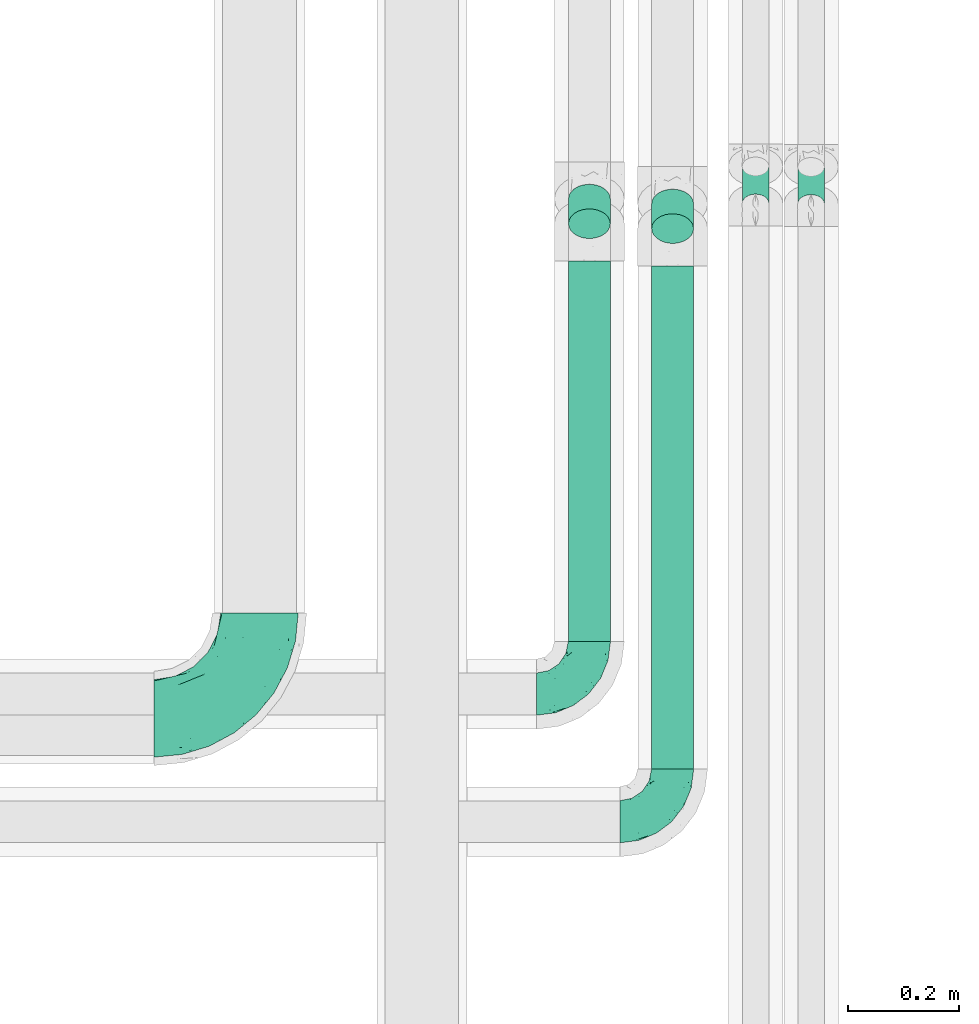
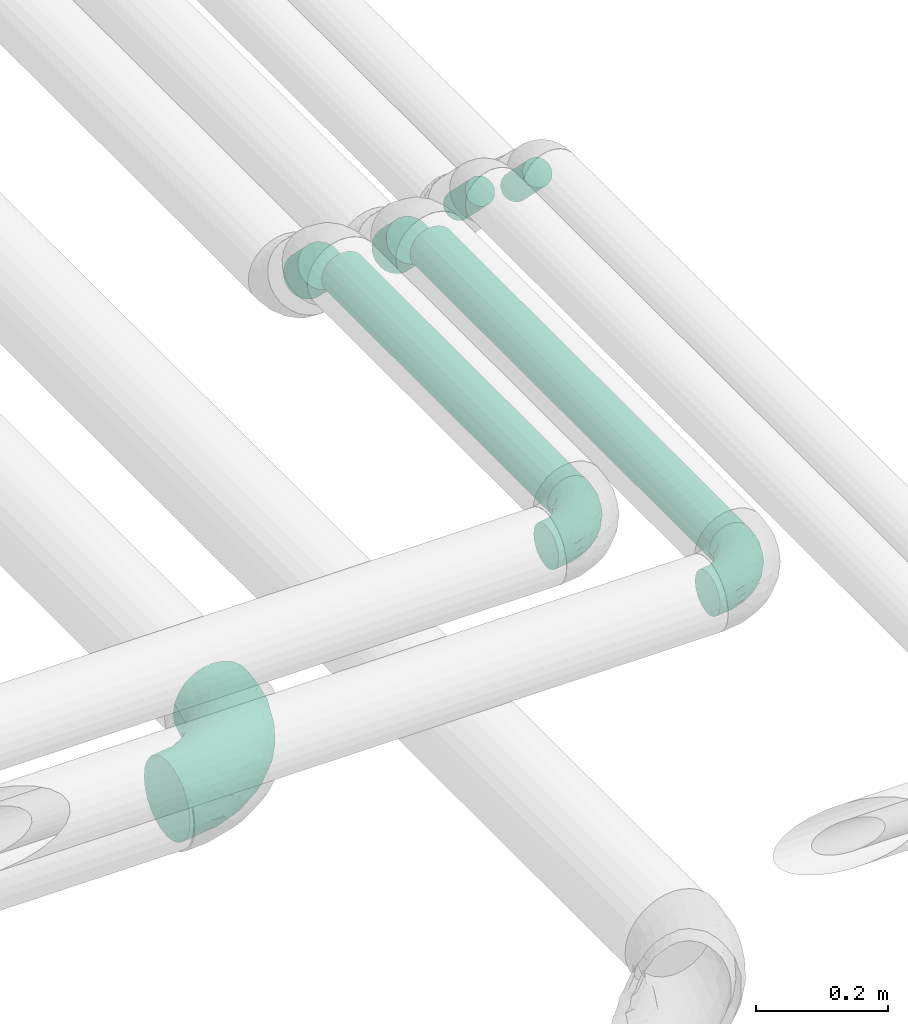
# One storey, part 723 of 827: 6 flow segments, 3 flow fittings.
"""IFC2X3 building model written with IfcOpenShell, lengths in millimetres."""

from ifc_helpers import new_model, entity, si_unit, converted_unit, derived_unit, direction, frame, origin, origin_2d_with_axis, place, context, subcontext, project, spatial, circle, extrude, faceted_brep, source, transform, mapped, material, type_object, type_shapes, element, save


model = new_model("IFC2X3")

# Units and contexts
model_context = context("Model", 3, precision=0.01, world=origin(), true_north=direction((6.12303176911189e-17, 1.0)))
body_context = subcontext(model_context, "Body", "Model", "MODEL_VIEW")
ifc_project = project(units=[si_unit("LENGTHUNIT", "METRE", prefix="MILLI"), si_unit("AREAUNIT", "SQUARE_METRE"), si_unit("VOLUMEUNIT", "CUBIC_METRE"), converted_unit("PLANEANGLEUNIT", "DEGREE", entity("IfcRatioMeasure", 0.0174532925199433), si_unit("PLANEANGLEUNIT", "RADIAN"), dimensions=[0, 0, 0, 0, 0, 0, 0]), si_unit("MASSUNIT", "GRAM", prefix="KILO"), derived_unit("MASSDENSITYUNIT", [(si_unit("MASSUNIT", "GRAM", prefix="KILO"), 1), (si_unit("LENGTHUNIT", "METRE"), -3)]), derived_unit("MOMENTOFINERTIAUNIT", [(si_unit("LENGTHUNIT", "METRE"), 4)]), si_unit("TIMEUNIT", "SECOND"), si_unit("FREQUENCYUNIT", "HERTZ"), si_unit("THERMODYNAMICTEMPERATUREUNIT", "DEGREE_CELSIUS"), derived_unit("THERMALTRANSMITTANCEUNIT", [(si_unit("MASSUNIT", "GRAM", prefix="KILO"), 1), (si_unit("THERMODYNAMICTEMPERATUREUNIT", "KELVIN"), -1), (si_unit("TIMEUNIT", "SECOND"), -3)]), derived_unit("VOLUMETRICFLOWRATEUNIT", [(si_unit("LENGTHUNIT", "METRE"), 3), (si_unit("TIMEUNIT", "SECOND"), -1)]), derived_unit("MASSFLOWRATEUNIT", [(si_unit("MASSUNIT", "GRAM", prefix="KILO"), 1), (si_unit("TIMEUNIT", "SECOND"), -1)]), derived_unit("ROTATIONALFREQUENCYUNIT", [(si_unit("TIMEUNIT", "SECOND"), -1)]), si_unit("ELECTRICCURRENTUNIT", "AMPERE"), si_unit("ELECTRICVOLTAGEUNIT", "VOLT"), si_unit("POWERUNIT", "WATT"), si_unit("FORCEUNIT", "NEWTON", prefix="KILO"), si_unit("ILLUMINANCEUNIT", "LUX"), si_unit("LUMINOUSFLUXUNIT", "LUMEN"), si_unit("LUMINOUSINTENSITYUNIT", "CANDELA"), derived_unit("USERDEFINED", [(si_unit("MASSUNIT", "GRAM", prefix="KILO"), -1), (si_unit("LENGTHUNIT", "METRE"), -2), (si_unit("TIMEUNIT", "SECOND"), 3), (si_unit("LUMINOUSFLUXUNIT", "LUMEN"), 1)]), derived_unit("LINEARVELOCITYUNIT", [(si_unit("LENGTHUNIT", "METRE"), 1), (si_unit("TIMEUNIT", "SECOND"), -1)]), si_unit("PRESSUREUNIT", "PASCAL"), derived_unit("USERDEFINED", [(si_unit("LENGTHUNIT", "METRE"), -2), (si_unit("MASSUNIT", "GRAM", prefix="KILO"), 1), (si_unit("TIMEUNIT", "SECOND"), -2)]), derived_unit("LINEARFORCEUNIT", [(si_unit("MASSUNIT", "GRAM", prefix="KILO"), 1), (si_unit("LENGTHUNIT", "METRE"), 1), (si_unit("TIMEUNIT", "SECOND"), -2), (si_unit("LENGTHUNIT", "METRE"), -1)]), derived_unit("PLANARFORCEUNIT", [(si_unit("MASSUNIT", "GRAM", prefix="KILO"), 1), (si_unit("LENGTHUNIT", "METRE"), 1), (si_unit("TIMEUNIT", "SECOND"), -2), (si_unit("LENGTHUNIT", "METRE"), -2)])], contexts=[model_context])

# Site, building, storey
site_placement = place(None, origin())
site = spatial("IfcSite", under=ifc_project, at=site_placement, CompositionType="ELEMENT")
building_placement = place(site_placement, origin())
building = spatial("IfcBuilding", under=site, at=building_placement, CompositionType="ELEMENT")
storey_placement = place(building_placement, frame((0.0, 0.0, 28200.0)))
storey = spatial("IfcBuildingStorey", under=building, at=storey_placement, Name="08", CompositionType="ELEMENT", Elevation=28200.0)

# Flow segments
pipe_segment_type = type_object("IfcPipeSegmentType", PredefinedType="NOTDEFINED")
flow_segment_1_placement = place(storey_placement, frame((61127.04, 8174.6, 2997.87)))
element("IfcFlowSegment", 1, at=flow_segment_1_placement, inside=storey, type_object=pipe_segment_type, context=body_context, shape_type="SweptSolid", body=[
    extrude(circle(Radius=24.0, at=origin_2d_with_axis()), frame((25.6, 18.57, 85.43), z_axis=(0.0, 0.707106781186422, -0.707106781186673), x_axis=(1.0, 0.0, 0.0)), (0.0, 0.0, 1.0), 94.5641960007422),
])
flow_segment_2_placement = place(storey_placement, frame((61027.04, 8175.51, 2997.87)))
element("IfcFlowSegment", 2, at=flow_segment_2_placement, inside=storey, type_object=pipe_segment_type, context=body_context, shape_type="SweptSolid", body=[
    extrude(circle(Radius=24.0, at=origin_2d_with_axis()), frame((25.6, 18.57, 85.43), z_axis=(0.0, 0.707106781186433, -0.707106781186662), x_axis=(1.0, 0.0, 0.0)), (0.0, 0.0, 1.0), 94.5641960007315),
])
flow_segment_3_placement = place(storey_placement, frame((60863.76, 7175.0, 3060.65)))
element("IfcFlowSegment", 3, at=flow_segment_3_placement, inside=storey, type_object=pipe_segment_type, context=body_context, shape_type="SweptSolid", body=[
    extrude(circle(Radius=37.75, at=origin_2d_with_axis()), frame((39.35, 0.0, 39.35), z_axis=(0.0, 1.0, 0.0), x_axis=(1.0, 0.0, 0.0)), (0.0, 0.0, 1.0), 906.837013694415),
])
flow_segment_4_placement = place(storey_placement, frame((60863.76, 8120.72, 2999.54)))
element("IfcFlowSegment", 4, at=flow_segment_4_placement, inside=storey, type_object=pipe_segment_type, context=body_context, shape_type="SweptSolid", body=[
    extrude(circle(Radius=37.75, at=origin_2d_with_axis()), frame((39.35, 72.64, 28.29), z_axis=(0.0, -0.707106781186349, 0.707106781186746), x_axis=(1.0, 0.0, 0.0)), (0.0, 0.0, 1.0), 62.7207793864235),
])
flow_segment_5_placement = place(storey_placement, frame((60713.76, 7405.0, 3060.65)))
element("IfcFlowSegment", 5, at=flow_segment_5_placement, inside=storey, type_object=pipe_segment_type, context=body_context, shape_type="SweptSolid", body=[
    extrude(circle(Radius=37.75, at=origin_2d_with_axis()), frame((39.35, 0.0, 39.35), z_axis=(0.0, 1.0, 0.0), x_axis=(1.0, 0.0, 0.0)), (0.0, 0.0, 1.0), 685.663833694496),
])
flow_segment_6_placement = place(storey_placement, frame((60713.76, 8129.55, 2999.54)))
element("IfcFlowSegment", 6, at=flow_segment_6_placement, inside=storey, type_object=pipe_segment_type, context=body_context, shape_type="SweptSolid", body=[
    extrude(circle(Radius=37.75, at=origin_2d_with_axis()), frame((39.35, 72.64, 28.29), z_axis=(0.0, -0.707106781186358, 0.707106781186737), x_axis=(1.0, 0.0, 0.0)), (0.0, 0.0, 1.0), 62.7207793864296),
])

# Flow fittings
ifc_material = material()
pipe_fitting_type_1 = type_object("IfcPipeFittingType", Name="ADSK_1", PredefinedType="NOTDEFINED", material=ifc_material)
shared_shape_1 = source(origin(), body_context, "Body", "Brep", [
    faceted_brep([(-95.0, 19.02, -32.95), (-95.0, 9.85, -36.75), (-95.0, 0.0, -38.05), (-95.0, -9.85, -36.75), (-95.0, -19.03, -32.95), (-95.0, -26.91, -26.91), (-95.0, -32.95, -19.03), (-95.0, -36.75, -9.85), (-95.0, -38.05, 0.0), (-95.0, -36.75, 9.85), (-95.0, -32.95, 19.02), (-95.0, -26.91, 26.91), (-95.0, -19.03, 32.95), (-95.0, -9.85, 36.75), (-95.0, 0.0, 38.05), (-95.0, 9.85, 36.75), (-95.0, 19.02, 32.95), (-95.0, 26.91, 26.91), (-95.0, 32.95, 19.02), (-95.0, 36.75, 9.85), (-95.0, 38.05, 0.0), (-95.0, 36.75, -9.85), (-95.0, 32.95, -19.03), (-95.0, 26.91, -26.91), (0.0, 95.0, -38.05), (-9.85, 95.0, -36.75), (-19.02, 95.0, -32.95), (-26.91, 95.0, -26.91), (-32.95, 95.0, -19.03), (-36.75, 95.0, -9.85), (-38.05, 95.0, 0.0), (-36.75, 95.0, 9.85), (-32.95, 95.0, 19.02), (-26.91, 95.0, 26.91), (-19.02, 95.0, 32.95), (-9.85, 95.0, 36.75), (0.0, 95.0, 38.05), (9.85, 95.0, 36.75), (19.03, 95.0, 32.95), (26.91, 95.0, 26.91), (32.95, 95.0, 19.02), (36.75, 95.0, 9.85), (38.05, 95.0, 0.0), (36.75, 95.0, -9.85), (32.95, 95.0, -19.03), (26.91, 95.0, -26.91), (19.03, 95.0, -32.95), (9.85, 95.0, -36.75), (-7.99, -4.96, 6.3), (-0.92, 0.92, 0.0), (4.62, 8.1, 8.01), (-76.19, -35.57, 0.0), (-64.32, -32.32, 12.43), (20.51, 62.45, 28.68), (-60.56, -33.52, 0.0), (-70.4, -13.47, 34.42), (-39.61, -5.88, 32.32), (-49.6, 2.07, 37.1), (-70.34, -28.81, 21.71), (14.64, 40.81, 26.5), (5.88, 39.61, 32.32), (3.59, 20.77, 25.31), (-40.45, 68.06, 16.75), (-62.45, -20.51, 28.68), (-44.52, -26.87, 0.0), (-28.47, -20.22, 0.0), (-26.43, -17.83, 8.75), (-76.1, 39.63, 10.76), (-72.74, 37.58, 18.19), (-60.35, 46.18, 14.61), (-13.4, 13.4, 32.12), (-20.77, -3.59, 25.31), (-14.66, 81.47, 35.56), (-6.22, 71.26, 37.92), (-57.5, 42.48, 22.79), (-15.0, 34.74, 37.7), (-27.1, 12.08, 36.05), (-9.2, 28.81, 35.63), (-79.98, 23.7, 30.95), (-73.68, -4.3, 37.48), (-30.74, 21.67, 37.97), (-62.36, 47.59, 6.79), (-72.71, 32.83, 24.69), (-67.42, 7.02, 37.95), (-32.13, 75.27, 24.51), (-43.46, 51.47, 26.26), (-24.98, 73.15, 31.29), (20.59, 41.28, 19.85), (7.79, 16.09, 15.86), (-73.21, 42.39, 0.0), (-54.73, 54.73, 0.0), (-73.44, 15.79, 35.79), (-5.94, 4.32, 20.43), (28.81, 70.34, 21.71), (32.32, 64.32, 12.43), (-53.59, 26.2, 35.09), (-52.02, 19.31, 37.21), (21.38, 33.53, 10.34), (26.87, 44.52, 0.0), (-48.28, 12.14, 38.05), (4.3, 73.68, 37.48), (-44.08, -25.52, 12.79), (-41.28, -20.59, 19.85), (35.57, 76.19, 0.0), (-47.26, 54.3, 20.18), (-47.4, 61.99, 8.58), (-42.39, 73.21, 0.0), (-39.67, 78.86, 7.21), (-45.69, 36.84, 33.11), (-32.83, 50.13, 33.35), (13.47, 70.4, 34.42), (-18.25, 63.73, 36.07), (-40.63, -13.75, 27.22), (-16.63, 46.37, 37.95), (-53.47, 38.79, 28.59), (-26.07, 48.54, 36.15), (-34.51, 34.51, 36.86), (-2.07, 49.6, 37.1), (-22.79, -10.49, 19.23), (-61.73, 28.67, 31.87), (9.65, 14.7, 0.0), (20.22, 28.47, 0.0), (33.52, 60.56, 0.0), (-11.42, -5.44, 13.25), (-14.7, -9.65, 0.0), (-81.47, 14.66, -35.56), (-62.45, -20.51, -28.68), (-71.26, 6.22, -37.92), (-75.27, 32.13, -24.51), (-73.15, 24.98, -31.29), (13.47, 70.4, -34.42), (5.88, 39.61, -32.32), (-2.07, 49.6, -37.1), (-78.86, 39.67, -7.21), (-70.4, -13.47, -34.42), (-39.61, -5.88, -32.32), (-61.99, 47.4, -8.58), (32.32, 64.32, -12.43), (28.81, 70.34, -21.71), (-63.73, 18.25, -36.07), (-50.13, 32.83, -33.35), (4.3, 73.68, -37.48), (-7.02, 67.42, -37.95), (-39.63, 76.1, -10.76), (-46.18, 60.35, -14.61), (-47.59, 62.36, -6.79), (-64.32, -32.32, -12.43), (-26.2, 53.59, -35.09), (-15.79, 73.44, -35.79), (-19.31, 52.02, -37.21), (-37.58, 72.74, -18.19), (-70.34, -28.81, -21.71), (-42.48, 57.5, -22.79), (-38.79, 53.47, -28.59), (-51.47, 43.46, -26.26), (-32.83, 72.71, -24.69), (-46.37, 16.63, -37.95), (-73.68, -4.3, -37.48), (-41.28, -20.59, -19.85), (-44.08, -25.52, -12.79), (13.75, 40.63, -27.22), (20.51, 62.45, -28.68), (-68.06, 40.45, -16.75), (-54.3, 47.26, -20.18), (-12.14, 48.28, -38.05), (-21.67, 30.74, -37.97), (-36.84, 45.69, -33.11), (-11.42, -5.44, -13.25), (7.79, 16.09, -15.86), (4.62, 8.1, -8.01), (-23.7, 79.98, -30.95), (-26.43, -17.83, -8.75), (-7.99, -4.96, -6.3), (-40.81, -14.64, -26.5), (-20.77, -3.59, -25.31), (-34.74, 15.0, -37.7), (-12.08, 27.1, -36.05), (-28.81, 9.2, -35.63), (-22.79, -10.49, -19.23), (21.38, 33.53, -10.34), (20.59, 41.28, -19.85), (-48.54, 26.07, -36.15), (-49.6, 2.07, -37.1), (-13.4, 13.4, -32.12), (3.59, 20.77, -25.31), (-28.67, 61.73, -31.87), (-34.51, 34.51, -36.86), (-5.94, 4.32, -20.43)], [[[0, 1, 2, 3, 4, 5, 6, 7, 8, 9, 10, 11, 12, 13, 14, 15, 16, 17, 18, 19, 20, 21, 22, 23]], [[24, 25, 26, 27, 28, 29, 30, 31, 32, 33, 34, 35, 36, 37, 38, 39, 40, 41, 42, 43, 44, 45, 46, 47]], [[48, 49, 50]], [[51, 52, 9]], [[53, 39, 38]], [[9, 52, 10]], [[54, 52, 51]], [[55, 56, 57]], [[11, 10, 58]], [[59, 60, 61]], [[32, 31, 62]], [[63, 12, 11]], [[63, 55, 12]], [[64, 65, 66]], [[67, 68, 69]], [[70, 56, 71]], [[35, 72, 73]], [[69, 68, 74]], [[75, 76, 77]], [[16, 78, 17]], [[13, 79, 14]], [[76, 75, 80]], [[67, 69, 81]], [[18, 17, 82]], [[14, 79, 83]], [[20, 19, 67]], [[84, 85, 86]], [[87, 61, 88]], [[89, 81, 90]], [[18, 82, 68]], [[15, 91, 16]], [[14, 83, 15]], [[71, 92, 61]], [[17, 78, 82]], [[93, 87, 94]], [[95, 91, 96]], [[97, 98, 94]], [[86, 72, 34]], [[96, 99, 80]], [[37, 36, 100]], [[40, 39, 93]], [[40, 94, 41]], [[64, 66, 101]], [[93, 94, 40]], [[58, 102, 63]], [[94, 103, 41]], [[94, 87, 97]], [[104, 69, 74]], [[34, 33, 86]], [[105, 69, 104]], [[52, 58, 10]], [[106, 107, 30]], [[108, 109, 85]], [[105, 106, 90]], [[53, 110, 60]], [[86, 111, 72]], [[86, 109, 111]], [[33, 84, 86]], [[12, 55, 13]], [[112, 56, 63]], [[110, 38, 37]], [[34, 72, 35]], [[36, 35, 73]], [[111, 113, 73]], [[105, 107, 106]], [[110, 53, 38]], [[74, 114, 85]], [[91, 15, 83]], [[105, 90, 81]], [[107, 62, 31]], [[33, 32, 84]], [[115, 109, 116]], [[111, 115, 113]], [[100, 73, 117]], [[56, 55, 63]], [[79, 55, 57]], [[102, 118, 112]], [[56, 70, 76]], [[100, 110, 37]], [[117, 77, 60]], [[117, 60, 110]], [[60, 70, 61]], [[58, 52, 101]], [[63, 11, 58]], [[39, 53, 93]], [[87, 93, 53]], [[96, 91, 83]], [[78, 91, 119]], [[32, 62, 84]], [[84, 62, 104]], [[86, 85, 109]], [[85, 114, 108]], [[80, 113, 116]], [[117, 73, 113]], [[80, 116, 96]], [[80, 57, 76]], [[71, 112, 118]], [[61, 87, 59]], [[62, 107, 105]], [[97, 120, 121]], [[70, 71, 61]], [[71, 118, 92]], [[73, 100, 36]], [[110, 100, 117]], [[55, 79, 13]], [[83, 79, 57]], [[96, 83, 99]], [[116, 108, 95]], [[50, 97, 88]], [[97, 87, 88]], [[50, 49, 120]], [[122, 94, 98]], [[89, 20, 67]], [[105, 81, 69]], [[89, 67, 81]], [[68, 19, 18]], [[68, 67, 19]], [[74, 68, 82]], [[114, 82, 119]], [[74, 85, 104]], [[82, 114, 74]], [[114, 119, 108]], [[95, 108, 119]], [[116, 109, 108]], [[123, 48, 50]], [[97, 50, 120]], [[123, 50, 88]], [[91, 95, 119]], [[116, 95, 96]], [[84, 104, 85]], [[104, 62, 105]], [[83, 57, 99]], [[57, 80, 99]], [[66, 48, 123]], [[66, 124, 48]], [[118, 66, 123]], [[124, 66, 65]], [[66, 118, 101]], [[54, 64, 52]], [[124, 49, 48]], [[30, 107, 31]], [[91, 78, 16]], [[82, 78, 119]], [[56, 76, 57]], [[77, 76, 70]], [[60, 77, 70]], [[77, 117, 75]], [[117, 113, 75]], [[113, 80, 75]], [[9, 8, 51]], [[103, 94, 122]], [[103, 42, 41]], [[73, 72, 111]], [[113, 115, 116]], [[111, 109, 115]], [[102, 112, 63]], [[71, 56, 112]], [[118, 102, 101]], [[92, 123, 88]], [[123, 92, 118]], [[61, 92, 88]], [[87, 53, 59]], [[60, 59, 53]], [[97, 121, 98]], [[58, 101, 102]], [[64, 101, 52]], [[125, 1, 0]], [[126, 5, 4]], [[2, 1, 127]], [[1, 125, 127]], [[128, 129, 23]], [[130, 131, 132]], [[89, 133, 20]], [[126, 134, 135]], [[136, 89, 90]], [[137, 138, 44]], [[139, 129, 140]], [[24, 141, 142]], [[143, 144, 145]], [[125, 129, 139]], [[6, 146, 7]], [[147, 148, 149]], [[146, 51, 7]], [[143, 150, 144]], [[146, 6, 151]], [[152, 153, 154]], [[126, 4, 134]], [[0, 23, 129]], [[28, 155, 150]], [[43, 42, 103]], [[54, 146, 64]], [[139, 156, 127]], [[157, 3, 2]], [[151, 158, 159]], [[160, 131, 161]], [[22, 21, 162]], [[136, 144, 163]], [[149, 164, 165]], [[24, 142, 25]], [[166, 140, 154]], [[154, 129, 128]], [[143, 30, 29]], [[167, 168, 169]], [[155, 28, 27]], [[26, 170, 27]], [[171, 167, 172]], [[26, 25, 148]], [[27, 170, 155]], [[173, 135, 174]], [[144, 150, 152]], [[175, 176, 177]], [[24, 47, 141]], [[45, 161, 46]], [[148, 25, 142]], [[176, 175, 165]], [[64, 159, 171]], [[138, 45, 44]], [[130, 46, 161]], [[137, 44, 43]], [[178, 159, 158]], [[137, 103, 122]], [[163, 144, 152]], [[136, 133, 89]], [[103, 137, 43]], [[6, 5, 151]], [[178, 158, 173]], [[134, 4, 3]], [[178, 173, 174]], [[137, 98, 179]], [[145, 90, 106]], [[138, 180, 161]], [[46, 130, 47]], [[136, 90, 145]], [[133, 162, 21]], [[23, 22, 128]], [[139, 140, 181]], [[139, 181, 156]], [[157, 127, 182]], [[157, 134, 3]], [[182, 177, 135]], [[182, 135, 134]], [[135, 183, 174]], [[131, 130, 161]], [[141, 130, 132]], [[160, 180, 184]], [[131, 183, 176]], [[5, 126, 151]], [[158, 151, 126]], [[180, 138, 137]], [[161, 45, 138]], [[149, 148, 142]], [[170, 148, 185]], [[22, 162, 128]], [[128, 162, 163]], [[129, 154, 140]], [[154, 153, 166]], [[165, 156, 186]], [[182, 127, 156]], [[165, 186, 149]], [[165, 132, 176]], [[131, 184, 183]], [[187, 167, 178]], [[184, 168, 187]], [[167, 169, 172]], [[184, 180, 168]], [[174, 183, 184]], [[127, 157, 2]], [[134, 157, 182]], [[130, 141, 47]], [[142, 141, 132]], [[149, 142, 164]], [[186, 166, 147]], [[180, 179, 168]], [[169, 179, 120]], [[137, 179, 180]], [[179, 121, 120]], [[106, 30, 143]], [[136, 145, 144]], [[106, 143, 145]], [[150, 29, 28]], [[150, 143, 29]], [[152, 150, 155]], [[153, 155, 185]], [[152, 154, 163]], [[155, 153, 152]], [[153, 185, 166]], [[147, 166, 185]], [[186, 140, 166]], [[169, 120, 49]], [[169, 49, 172]], [[179, 169, 168]], [[148, 147, 185]], [[186, 147, 149]], [[128, 163, 154]], [[163, 162, 136]], [[142, 132, 164]], [[132, 165, 164]], [[171, 124, 65]], [[124, 171, 172]], [[64, 146, 159]], [[171, 159, 178]], [[171, 65, 64]], [[172, 49, 124]], [[162, 133, 136]], [[20, 133, 21]], [[148, 170, 26]], [[155, 170, 185]], [[131, 176, 132]], [[177, 176, 183]], [[135, 177, 183]], [[177, 182, 175]], [[182, 156, 175]], [[156, 165, 175]], [[51, 146, 54]], [[51, 8, 7]], [[129, 125, 0]], [[127, 125, 139]], [[140, 186, 181]], [[156, 181, 186]], [[158, 126, 173]], [[135, 173, 126]], [[187, 178, 174]], [[171, 178, 167]], [[184, 187, 174]], [[167, 187, 168]], [[180, 160, 161]], [[184, 131, 160]], [[98, 137, 122]], [[98, 121, 179]], [[151, 159, 146]]]),
])
type_shapes(pipe_fitting_type_1, [shared_shape_1])
for number, where, name in (
    (7, (60903.1, 7080.0, 3100.0), "ADSK_1"),
    (8, (60753.1, 7310.0, 3100.0), "ADSK_1"),
):
    element("IfcFlowFitting", number, at=place(storey_placement, frame(where)), inside=storey, type_object=pipe_fitting_type_1, material=ifc_material, Name=name, ObjectType="ADSK_1", context=body_context, shape_type="MappedRepresentation", body=[
        mapped(shared_shape_1, transform((0.0, 0.0, 0.0), scale=1.0)),
    ])
pipe_fitting_type_2 = type_object("IfcPipeFittingType", Name="ADSK_1", PredefinedType="NOTDEFINED", material=ifc_material)
shared_shape_2 = source(origin(), body_context, "Body", "Brep", [
    faceted_brep([(-190.0, 18.08, -67.47), (-190.0, 0.0, -69.85), (-190.0, -18.08, -67.47), (-190.0, -34.93, -60.49), (-190.0, -49.39, -49.39), (-190.0, -60.49, -34.93), (-190.0, -67.47, -18.08), (-190.0, -69.85, 0.0), (-190.0, -67.47, 18.08), (-190.0, -60.49, 34.92), (-190.0, -49.39, 49.39), (-190.0, -34.93, 60.49), (-190.0, -18.08, 67.47), (-190.0, 0.0, 69.85), (-190.0, 18.08, 67.47), (-190.0, 34.92, 60.49), (-190.0, 49.39, 49.39), (-190.0, 60.49, 34.92), (-190.0, 67.47, 18.08), (-190.0, 69.85, 0.0), (-190.0, 67.47, -18.08), (-190.0, 60.49, -34.93), (-190.0, 49.39, -49.39), (-190.0, 34.92, -60.49), (18.08, 190.0, -67.47), (0.0, 190.0, -69.85), (-18.08, 190.0, -67.47), (-34.92, 190.0, -60.49), (-49.39, 190.0, -49.39), (-60.49, 190.0, -34.93), (-67.47, 190.0, -18.08), (-69.85, 190.0, 0.0), (-67.47, 190.0, 18.08), (-60.49, 190.0, 34.92), (-49.39, 190.0, 49.39), (-34.92, 190.0, 60.49), (-18.08, 190.0, 67.47), (0.0, 190.0, 69.85), (18.08, 190.0, 67.47), (34.93, 190.0, 60.49), (49.39, 190.0, 49.39), (60.49, 190.0, 34.92), (67.47, 190.0, 18.08), (69.85, 190.0, 0.0), (67.47, 190.0, -18.08), (60.49, 190.0, -34.93), (49.39, 190.0, -49.39), (34.93, 190.0, -60.49), (-29.62, 146.98, 65.62), (-13.75, 135.37, 69.64), (-124.22, -36.33, 52.83), (-140.23, -52.18, 40.04), (-80.56, -34.09, 36.78), (-140.97, -24.01, 63.29), (-80.93, -8.05, 59.8), (-100.59, 5.62, 68.24), (-125.19, -57.65, 22.9), (-139.31, -64.86, 0.0), (-28.7, -8.91, 22.6), (-45.64, -26.06, 0.0), (-6.26, 6.26, 0.0), (-105.44, 36.89, 68.2), (-118.83, 43.56, 64.34), (-146.98, 29.62, 65.62), (-71.47, -38.86, 17.07), (-90.56, -50.07, 0.0), (-0.6, 27.02, 35.97), (-44.76, -2.31, 47.74), (-42.86, -12.1, 35.78), (-148.03, -7.38, 68.85), (-135.37, 13.75, 69.64), (-67.48, 159.11, 28.79), (36.32, 124.15, 52.82), (-38.8, 102.11, 68.2), (-24.59, 96.61, 69.85), (-81.73, 130.22, 21.92), (-65.15, 30.31, 68.68), (-27.72, 54.52, 66.49), (-44.98, 61.25, 69.74), (-75.73, 152.87, 0.0), (-159.11, 67.48, 28.79), (-130.22, 81.73, 21.92), (-152.87, 75.73, 0.0), (-76.65, 126.59, 35.57), (-101.51, 101.51, 25.92), (-96.74, 96.74, 38.75), (-144.94, 60.97, 45.11), (-159.57, 43.91, 56.71), (-119.38, 92.8, 0.0), (50.07, 90.56, 0.0), (57.42, 124.25, 22.84), (38.8, 71.6, 17.49), (64.86, 139.31, 0.0), (52.17, 140.21, 40.03), (33.37, 79.39, 36.99), (24.0, 140.95, 63.29), (8.03, 80.92, 59.81), (-82.61, -22.17, 50.94), (7.38, 148.03, 68.85), (-100.26, 79.14, 51.33), (-75.76, 96.1, 55.72), (-76.12, 111.95, 46.7), (-92.8, 119.38, 0.0), (-104.27, 104.27, 12.31), (10.07, 27.17, 16.15), (26.06, 45.64, 0.0), (-61.21, 144.14, 45.16), (-44.13, 158.15, 56.77), (-55.26, 120.41, 58.38), (9.95, 57.03, 48.64), (29.48, 90.08, 47.56), (-5.62, 100.59, 68.24), (-122.78, 54.24, 58.28), (-86.25, 73.26, 61.12), (-95.79, 24.47, 69.85), (-126.59, 76.65, 35.57), (-17.15, 26.56, 50.85), (-29.82, 29.82, 59.54), (-70.73, 11.02, 65.19), (-58.6, 94.58, 64.16), (-71.14, 66.1, 67.41), (-158.15, 44.13, -56.77), (33.37, 79.39, -36.99), (10.07, 27.17, -16.15), (-0.6, 27.02, -35.97), (-100.59, 5.62, -68.24), (-148.03, -7.38, -68.85), (-135.37, 13.75, -69.64), (-130.22, 81.73, -21.92), (-146.98, 29.62, -65.62), (-102.11, 38.8, -68.2), (-96.61, 24.59, -69.85), (-83.02, -24.86, -48.76), (-44.76, -2.31, -47.74), (-80.56, -34.09, -36.78), (-122.68, -57.24, -22.15), (-71.43, -38.87, -16.95), (-104.27, 104.27, -12.31), (-159.11, 67.48, -28.79), (-144.14, 61.21, -45.16), (7.38, 148.03, -68.85), (-13.75, 135.37, -69.64), (-79.14, 100.26, -51.33), (-96.1, 75.76, -55.72), (-111.95, 76.12, -46.7), (-80.93, -8.05, -59.8), (-124.22, -36.33, -52.83), (-140.23, -52.18, -40.04), (-24.47, 95.79, -69.85), (-36.89, 105.44, -68.2), (-150.18, -65.36, -13.92), (-43.56, 118.83, -64.34), (-29.62, 146.98, -65.62), (38.8, 71.6, -17.49), (-81.73, 130.22, -21.92), (-28.7, -8.91, -22.6), (-54.24, 122.78, -58.28), (-73.26, 86.25, -61.12), (-61.25, 44.98, -69.74), (-30.31, 65.15, -68.68), (-54.52, 27.72, -66.49), (-101.51, 101.51, -25.92), (-126.59, 76.65, -35.57), (-96.74, 96.74, -38.75), (-67.48, 159.11, -28.79), (-120.41, 55.26, -58.38), (-43.91, 159.57, -56.71), (24.0, 140.95, -63.29), (8.03, 80.92, -59.81), (-5.62, 100.59, -68.24), (-60.97, 144.94, -45.11), (36.32, 124.15, -52.82), (57.42, 124.25, -22.84), (52.17, 140.21, -40.03), (-140.97, -24.01, -63.29), (9.95, 57.03, -48.64), (-76.65, 126.59, -35.57), (22.84, 89.04, -52.94), (-11.03, 70.74, -65.2), (-29.82, 29.82, -59.54), (-94.58, 58.6, -64.16), (-66.1, 71.14, -67.41), (-31.42, -3.01, -36.09), (-13.88, 24.32, -46.86)], [[[0, 1, 2, 3, 4, 5, 6, 7, 8, 9, 10, 11, 12, 13, 14, 15, 16, 17, 18, 19, 20, 21, 22, 23]], [[24, 25, 26, 27, 28, 29, 30, 31, 32, 33, 34, 35, 36, 37, 38, 39, 40, 41, 42, 43, 44, 45, 46, 47]], [[36, 48, 49]], [[50, 51, 52]], [[53, 54, 55]], [[56, 9, 8]], [[8, 7, 57]], [[58, 59, 60]], [[51, 9, 56]], [[61, 62, 63]], [[59, 58, 64]], [[59, 64, 65]], [[11, 10, 50]], [[66, 67, 68]], [[50, 53, 11]], [[69, 70, 13]], [[71, 33, 32]], [[72, 40, 39]], [[73, 74, 49]], [[63, 15, 14]], [[13, 70, 14]], [[71, 32, 75]], [[12, 69, 13]], [[76, 77, 78]], [[32, 79, 75]], [[18, 80, 81]], [[63, 14, 70]], [[82, 19, 18]], [[83, 84, 85]], [[86, 16, 87]], [[82, 81, 88]], [[82, 18, 81]], [[15, 87, 16]], [[83, 71, 75]], [[52, 56, 64]], [[49, 37, 36]], [[89, 90, 91]], [[36, 35, 48]], [[42, 41, 90]], [[89, 92, 90]], [[11, 53, 12]], [[73, 78, 74]], [[65, 56, 57]], [[40, 72, 93]], [[94, 90, 93]], [[41, 40, 93]], [[72, 95, 96]], [[95, 39, 38]], [[8, 57, 56]], [[43, 42, 92]], [[67, 54, 97]], [[38, 37, 98]], [[99, 100, 101]], [[102, 75, 79]], [[51, 10, 9]], [[102, 88, 103]], [[31, 79, 32]], [[104, 60, 105]], [[106, 34, 33]], [[84, 103, 81]], [[91, 105, 89]], [[107, 35, 34]], [[106, 108, 107]], [[49, 48, 73]], [[104, 105, 91]], [[16, 86, 17]], [[58, 104, 66]], [[109, 110, 96]], [[111, 98, 49]], [[112, 113, 99]], [[92, 42, 90]], [[95, 72, 39]], [[70, 114, 61]], [[80, 18, 17]], [[101, 106, 83]], [[99, 86, 112]], [[115, 81, 80]], [[90, 94, 91]], [[94, 66, 104]], [[64, 58, 68]], [[56, 65, 64]], [[93, 72, 110]], [[90, 41, 93]], [[98, 95, 38]], [[111, 77, 96]], [[111, 96, 95]], [[67, 116, 117]], [[52, 51, 56]], [[50, 10, 51]], [[54, 53, 50]], [[69, 53, 55]], [[97, 52, 67]], [[118, 76, 55]], [[107, 48, 35]], [[73, 119, 120]], [[61, 63, 70]], [[63, 62, 87]], [[94, 104, 91]], [[58, 60, 104]], [[109, 66, 94]], [[67, 117, 54]], [[68, 67, 52]], [[116, 66, 109]], [[119, 48, 108]], [[73, 120, 78]], [[120, 61, 114]], [[78, 114, 76]], [[49, 98, 37]], [[95, 98, 111]], [[53, 69, 12]], [[70, 69, 55]], [[70, 55, 114]], [[120, 113, 62]], [[76, 114, 55]], [[120, 114, 78]], [[118, 55, 54]], [[76, 118, 77]], [[96, 77, 117]], [[111, 78, 77]], [[54, 117, 118]], [[77, 118, 117]], [[110, 109, 94]], [[116, 96, 117]], [[106, 107, 34]], [[48, 107, 108]], [[75, 84, 83]], [[106, 33, 71]], [[101, 83, 85]], [[106, 71, 83]], [[99, 101, 85]], [[108, 106, 101]], [[99, 85, 115]], [[113, 112, 62]], [[119, 113, 120]], [[100, 99, 113]], [[17, 86, 80]], [[115, 85, 84]], [[80, 86, 115]], [[99, 115, 86]], [[63, 87, 15]], [[86, 87, 112]], [[78, 111, 74]], [[111, 49, 74]], [[119, 100, 113]], [[101, 100, 108]], [[48, 119, 73]], [[119, 108, 100]], [[75, 102, 103]], [[115, 84, 81]], [[81, 103, 88]], [[75, 103, 84]], [[54, 50, 97]], [[52, 97, 50]], [[64, 68, 52]], [[66, 68, 58]], [[62, 61, 120]], [[87, 62, 112]], [[93, 110, 94]], [[96, 110, 72]], [[66, 116, 67]], [[96, 116, 109]], [[22, 121, 23]], [[122, 123, 124]], [[125, 126, 127]], [[20, 82, 128]], [[129, 130, 127]], [[130, 131, 127]], [[19, 82, 20]], [[132, 133, 134]], [[88, 128, 82]], [[135, 136, 65]], [[102, 137, 88]], [[138, 20, 128]], [[139, 22, 21]], [[140, 141, 25]], [[142, 143, 144]], [[145, 133, 132]], [[4, 146, 147]], [[141, 148, 149]], [[7, 6, 150]], [[138, 21, 20]], [[5, 4, 147]], [[149, 151, 152]], [[59, 65, 136]], [[122, 153, 123]], [[79, 30, 154]], [[134, 155, 136]], [[150, 65, 57]], [[156, 157, 142]], [[126, 2, 1]], [[134, 135, 147]], [[130, 158, 131]], [[159, 160, 158]], [[154, 161, 137]], [[0, 23, 129]], [[127, 1, 0]], [[162, 138, 128]], [[161, 163, 162]], [[30, 79, 31]], [[146, 4, 3]], [[154, 30, 164]], [[152, 27, 26]], [[165, 121, 139]], [[25, 24, 140]], [[25, 141, 26]], [[164, 30, 29]], [[27, 166, 28]], [[167, 168, 169]], [[141, 152, 26]], [[28, 170, 29]], [[47, 171, 167]], [[172, 89, 153]], [[59, 155, 60]], [[28, 166, 170]], [[46, 45, 173]], [[153, 89, 105]], [[105, 123, 153]], [[174, 146, 3]], [[171, 47, 46]], [[45, 44, 172]], [[7, 150, 57]], [[43, 92, 44]], [[122, 124, 175]], [[89, 172, 92]], [[171, 173, 122]], [[47, 167, 24]], [[173, 171, 46]], [[135, 150, 5]], [[0, 129, 127]], [[174, 3, 2]], [[79, 154, 102]], [[146, 174, 145]], [[44, 92, 172]], [[144, 139, 162]], [[142, 170, 156]], [[176, 154, 164]], [[105, 60, 123]], [[122, 172, 153]], [[45, 172, 173]], [[122, 173, 172]], [[167, 171, 177]], [[140, 167, 169]], [[177, 122, 175]], [[178, 159, 169]], [[134, 136, 135]], [[155, 59, 136]], [[134, 147, 146]], [[135, 5, 147]], [[126, 174, 2]], [[125, 160, 145]], [[125, 145, 174]], [[145, 179, 133]], [[121, 129, 23]], [[130, 180, 181]], [[149, 152, 141]], [[152, 151, 166]], [[60, 155, 123]], [[123, 155, 124]], [[182, 134, 133]], [[175, 179, 168]], [[183, 179, 175]], [[155, 182, 124]], [[180, 129, 165]], [[130, 181, 158]], [[181, 149, 148]], [[158, 148, 159]], [[127, 126, 1]], [[174, 126, 125]], [[167, 140, 24]], [[141, 140, 169]], [[141, 169, 148]], [[181, 157, 151]], [[159, 148, 169]], [[181, 148, 158]], [[178, 169, 168]], [[159, 178, 160]], [[145, 160, 179]], [[125, 158, 160]], [[168, 179, 178]], [[160, 178, 179]], [[175, 124, 183]], [[177, 175, 168]], [[139, 121, 22]], [[129, 121, 165]], [[128, 161, 162]], [[139, 21, 138]], [[144, 162, 163]], [[139, 138, 162]], [[142, 144, 163]], [[165, 139, 144]], [[142, 163, 176]], [[157, 156, 151]], [[180, 157, 181]], [[143, 142, 157]], [[29, 170, 164]], [[176, 163, 161]], [[164, 170, 176]], [[142, 176, 170]], [[152, 166, 27]], [[170, 166, 156]], [[158, 125, 131]], [[125, 127, 131]], [[180, 143, 157]], [[144, 143, 165]], [[129, 180, 130]], [[180, 165, 143]], [[128, 88, 137]], [[176, 161, 154]], [[154, 137, 102]], [[128, 137, 161]], [[5, 150, 6]], [[65, 150, 135]], [[134, 146, 132]], [[145, 132, 146]], [[134, 182, 155]], [[183, 182, 133]], [[151, 149, 181]], [[166, 151, 156]], [[182, 183, 124]], [[179, 183, 133]], [[167, 177, 168]], [[122, 177, 171]]]),
])
type_shapes(pipe_fitting_type_2, [shared_shape_2])
flow_fitting_placement = place(storey_placement, frame((60158.54, 7266.2, 2899.96)))
element("IfcFlowFitting", 9, at=flow_fitting_placement, inside=storey, type_object=pipe_fitting_type_2, material=ifc_material, Name="ADSK_1", ObjectType="ADSK_1", context=body_context, shape_type="MappedRepresentation", body=[
    mapped(shared_shape_2, transform((0.0, 0.0, 0.0), scale=1.0)),
])

save(model, "model.ifc")
